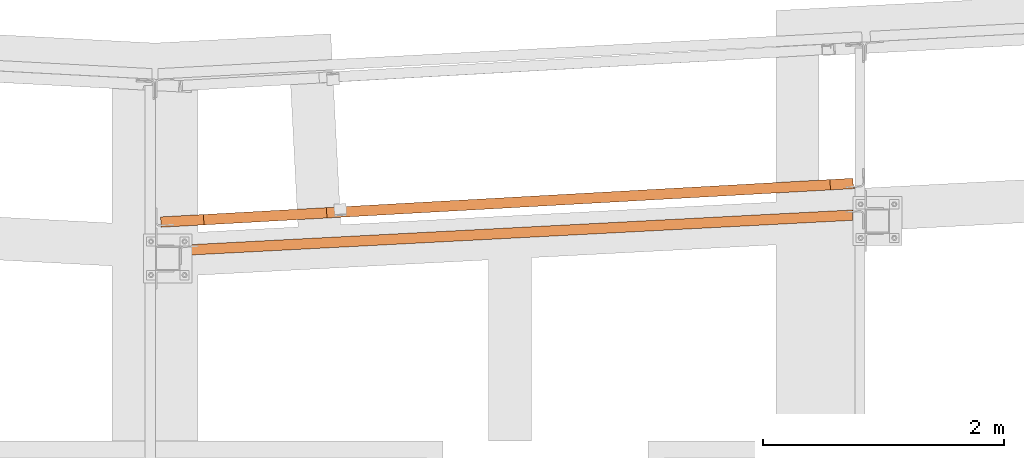
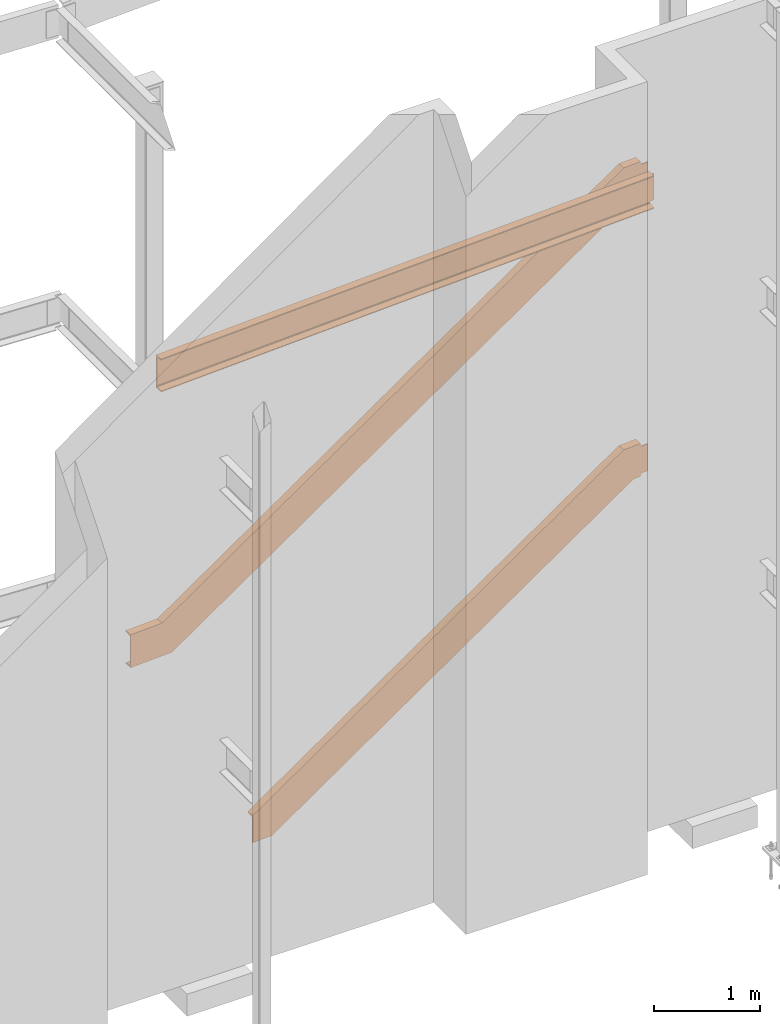
# One storey, part 15 of 89: 3 proxies.
"""IFC4 building model written with IfcOpenShell, lengths in feet."""

from ifc_helpers import new_model, entity, si_unit, converted_unit, derived_unit, direction, frame, origin, place, context, subcontext, project, spatial, face_set, faceted_brep, surface_model, source, transform, mapped, material, constituent, constituent_set, type_object, type_shapes, element, save


model = new_model("IFC4")

# Units and contexts
model_context = context("Model", 3, precision=0.0001, world=origin(), true_north=direction((6.12303176911189e-17, 1.0)))
body_context = subcontext(model_context, "Body", "Model", "MODEL_VIEW")
ifc_project = project(units=[converted_unit("LENGTHUNIT", "FOOT", entity("IfcRatioMeasure", 0.3048), si_unit("LENGTHUNIT", "METRE"), dimensions=[1, 0, 0, 0, 0, 0, 0]), converted_unit("AREAUNIT", "SQUARE FOOT", entity("IfcRatioMeasure", 0.09290304), si_unit("AREAUNIT", "SQUARE_METRE"), dimensions=[2, 0, 0, 0, 0, 0, 0]), converted_unit("VOLUMEUNIT", "CUBIC FOOT", entity("IfcRatioMeasure", 0.028316846592), si_unit("VOLUMEUNIT", "CUBIC_METRE"), dimensions=[3, 0, 0, 0, 0, 0, 0]), si_unit("PLANEANGLEUNIT", "RADIAN"), si_unit("MASSUNIT", "GRAM", prefix="KILO"), derived_unit("MASSDENSITYUNIT", [(si_unit("MASSUNIT", "GRAM", prefix="KILO"), 1), (si_unit("LENGTHUNIT", "METRE"), -3)]), derived_unit("MOMENTOFINERTIAUNIT", [(si_unit("LENGTHUNIT", "METRE"), 4)]), si_unit("TIMEUNIT", "SECOND"), si_unit("FREQUENCYUNIT", "HERTZ"), si_unit("THERMODYNAMICTEMPERATUREUNIT", "DEGREE_CELSIUS"), derived_unit("THERMALTRANSMITTANCEUNIT", [(si_unit("MASSUNIT", "GRAM", prefix="KILO"), 1), (si_unit("THERMODYNAMICTEMPERATUREUNIT", "KELVIN"), -1), (si_unit("TIMEUNIT", "SECOND"), -3)]), derived_unit("VOLUMETRICFLOWRATEUNIT", [(si_unit("LENGTHUNIT", "METRE"), 3), (si_unit("TIMEUNIT", "SECOND"), -1)]), si_unit("ELECTRICCURRENTUNIT", "AMPERE"), si_unit("ELECTRICVOLTAGEUNIT", "VOLT"), si_unit("POWERUNIT", "WATT"), si_unit("FORCEUNIT", "NEWTON"), si_unit("ILLUMINANCEUNIT", "LUX"), si_unit("LUMINOUSFLUXUNIT", "LUMEN"), si_unit("LUMINOUSINTENSITYUNIT", "CANDELA"), derived_unit("USERDEFINED", [(si_unit("MASSUNIT", "GRAM", prefix="KILO"), -1), (si_unit("LENGTHUNIT", "METRE"), -2), (si_unit("TIMEUNIT", "SECOND"), 3), (si_unit("LUMINOUSFLUXUNIT", "LUMEN"), 1)]), derived_unit("LINEARVELOCITYUNIT", [(si_unit("LENGTHUNIT", "METRE"), 1), (si_unit("TIMEUNIT", "SECOND"), -1)]), si_unit("PRESSUREUNIT", "PASCAL"), derived_unit("USERDEFINED", [(si_unit("LENGTHUNIT", "METRE"), -2), (si_unit("MASSUNIT", "GRAM", prefix="KILO"), 1), (si_unit("TIMEUNIT", "SECOND"), -2)]), derived_unit("LINEARFORCEUNIT", [(si_unit("MASSUNIT", "GRAM", prefix="KILO"), 1), (si_unit("LENGTHUNIT", "METRE"), 1), (si_unit("TIMEUNIT", "SECOND"), -2), (si_unit("LENGTHUNIT", "METRE"), -1)]), derived_unit("PLANARFORCEUNIT", [(si_unit("MASSUNIT", "GRAM", prefix="KILO"), 1), (si_unit("LENGTHUNIT", "METRE"), 1), (si_unit("TIMEUNIT", "SECOND"), -2), (si_unit("LENGTHUNIT", "METRE"), -2)])], contexts=[model_context])

# Site, building, storey
site_placement = place(None, origin())
site = spatial("IfcSite", under=ifc_project, at=site_placement, CompositionType="ELEMENT")
building_placement = place(site_placement, frame((-472.238160486, -49.138065117, 0.0)))
building = spatial("IfcBuilding", under=site, at=building_placement, CompositionType="ELEMENT")
storey_placement = place(building_placement, origin())
storey = spatial("IfcBuildingStorey", under=building, at=storey_placement, Name="Level 1", CompositionType="ELEMENT", Elevation=0.0)

# Proxies
ifc_material_1 = material(Name="Color 7720", Category="Materials")
ifc_material_2 = material()
ifc_constituent_1 = constituent(ifc_material_2)
ifc_constituent_2 = constituent(ifc_material_1, Name="Color 7720", Category="Materials")
ifc_constituent_set_1 = constituent_set(constituents=[ifc_constituent_1, ifc_constituent_2])
building_element_proxy_type_1 = type_object("IfcBuildingElementProxyType", Name="46B1", PredefinedType="NOTDEFINED", material=ifc_constituent_set_1)
shared_shape_1 = source(origin(), body_context, "Body", "Brep", [
    faceted_brep([(0.0, 0.282945034847103, 1.25000000000001), (0.0, 0.282945034847103, 0.0), (0.0148285209357653, 0.0, 0.0), (0.0148285209357653, 0.0, 0.0333340558078916), (0.00405689048207591, 0.20553495303659, 0.0676357025785599), (0.00314508419060644, 0.222933253516999, 0.0738152303317001), (0.00240032733219664, 0.2371440609312, 0.0856142600983816), (0.00191364833361263, 0.246430449426384, 0.101590647231962), (0.00174453187503332, 0.249657383688714, 0.119791666666682), (0.00174453187503332, 0.249657383688714, 1.13020833333334), (0.00191364833361263, 0.246430449426384, 1.14840935276806), (0.00240032733219664, 0.2371440609312, 1.16438573990165), (0.00314508419060644, 0.222933253516999, 1.17618476966832), (0.00405689048207591, 0.20553495303659, 1.18236429742146), (0.0148285209357653, 0.0, 1.21666594419213), (0.0148285209357653, 0.0, 1.25000000000001), (18.339448172324, 1.24407478683509, 0.125000000000011), (18.339448172324, 1.24407478683509, 1.12500000000001), (18.3411927041988, 1.2107871356767, 1.12500000000001), (18.3411927041988, 1.2107871356767, 0.125000000000011), (18.219500971703, 1.2377886204174, 0.12182831385465), (18.2060018576239, 1.23708116182615, 0.11279611588278), (18.1969820379655, 1.23660845310826, 0.0992784763485517), (18.1938146985057, 1.23644245988089, 0.0833333333333393), (18.1938146985057, 1.23644245988066, 0.0), (18.1938146985056, 1.23644245988419, 1.25000000000001), (18.1938146985056, 1.23644245988396, 1.16666666666668), (18.1969820379653, 1.23660845311122, 1.15072152365147), (18.2060018576237, 1.237081161829, 1.13720388411724), (18.2195009717029, 1.23778862042013, 1.12817168614537), (18.2354242624537, 1.23862312472727, 1.12500000000001), (18.2354242624539, 1.23862312472454, 0.125000000000011), (18.1989937882445, 0.952991719775582, 0.0), (18.1989937775088, 1.13761974550619, 0.0), (18.1989937882445, 0.952991719775582, 0.0333340558078916), (18.1989937775088, 1.13761974550619, 0.0640621568245159), (18.1978715889875, 1.15903237807242, 0.0676357025784746), (18.196959782696, 1.17643067855295, 0.0738152303317001), (18.196668108594, 1.19066523102822, 0.0856142600983496), (18.1963589983409, 1.1878943269528, 0.0833333333332895), (18.2004385121993, 1.20017472376878, 0.101590647231976), (18.198966120559, 1.19874990194103, 0.0992784763484948), (18.218201622917, 1.20434144623505, 0.119791666666675), (18.2078113893069, 1.20255324044263, 0.112796115882794), (18.2371687943283, 1.20533547357104, 0.125000000000011), (18.2371687943283, 1.20533547357104, 1.12500000000001), (18.2212455035775, 1.2045009692639, 1.12817168614537), (18.2182016229168, 1.20434144623812, 1.13020833333334), (18.2212455035775, 1.2045009692639, 0.12182831385465), (18.2004385121993, 1.20017472376878, 1.14840935276808), (18.2078113893069, 1.20255324044263, 1.13720388411722), (18.196668108594, 1.19066523102811, 1.16438573990163), (18.198966120559, 1.19874990194114, 1.15072152365151), (18.196959782696, 1.17643067855295, 1.17618476966827), (18.1963589983409, 1.18789432695269, 1.16666666666673), (18.1978715889875, 1.15903237807242, 1.18236429742152), (18.1989937882445, 0.952991719775582, 1.21666594419215), (18.1989937775088, 1.13761974550619, 1.18593784317547), (18.1989937882445, 0.952991719775582, 1.25000000000001), (18.1989937775088, 1.13761974550619, 1.25000000000001)], [[[0, 1, 2, 3, 4, 5, 6, 7, 8, 9, 10, 11, 12, 13, 14, 15]], [[16, 17, 18, 19]], [[20, 21, 22, 23, 24, 1, 0, 25, 26, 27, 28, 29, 30, 17, 16, 31]], [[32, 2, 1, 24, 33]], [[34, 3, 2, 32]], [[35, 36, 4, 3, 34]], [[37, 5, 4, 36]], [[38, 6, 5, 37, 39]], [[40, 7, 6, 38, 41]], [[42, 8, 7, 40, 43]], [[44, 19, 18, 45, 46, 47, 9, 8, 42, 48]], [[49, 10, 9, 47, 50]], [[51, 11, 10, 49, 52]], [[53, 12, 11, 51, 54]], [[55, 13, 12, 53]], [[56, 14, 13, 55, 57]], [[58, 15, 14, 56]], [[59, 25, 0, 15, 58]], [[57, 59, 25, 26, 54, 53, 55]], [[52, 27, 26, 54, 51]], [[50, 28, 27, 52, 49]], [[46, 29, 28, 50, 47]], [[29, 46, 45, 30]], [[17, 30, 45, 18]], [[59, 58, 56, 57]], [[19, 44, 31, 16]], [[48, 20, 31, 44]], [[43, 21, 20, 48, 42]], [[41, 22, 21, 43, 40]], [[39, 23, 22, 41, 38]], [[33, 24, 23, 39, 37, 36, 35]], [[34, 32, 33, 35]]]),
])
type_shapes(building_element_proxy_type_1, [shared_shape_1])
proxy_1_placement = place(building_placement, frame((231.291038536762, 1013.05140014163, 19.0208333333333)))
element("IfcBuildingElementProxy", 1, at=proxy_1_placement, inside=storey, type_object=building_element_proxy_type_1, material=ifc_material_1, Name="46B1:46B1", ObjectType="46B1:46B1", PredefinedType="NOTDEFINED", context=body_context, shape_type="MappedRepresentation", body=[
    mapped(shared_shape_1, transform((0.0, 0.0, 0.0), scale=1.0)),
])
ifc_material_3 = material(Name="Color 7718", Category="Materials")
ifc_constituent_3 = constituent(ifc_material_3, Name="Color 7718", Category="Materials")
ifc_constituent_4 = constituent(ifc_material_1, Name="Color 7720", Category="Materials")
ifc_constituent_set_2 = constituent_set(constituents=[ifc_constituent_3, ifc_constituent_4])
ifc_constituent_5 = constituent(ifc_material_2)
ifc_constituent_6 = constituent(ifc_material_3, Name="Color 7718", Category="Materials")
ifc_constituent_set_3 = constituent_set(constituents=[ifc_constituent_5, ifc_constituent_6])
building_element_proxy_type_2 = type_object("IfcBuildingElementProxyType", Name="c633", PredefinedType="NOTDEFINED", material=ifc_constituent_set_3)
shared_shape_2 = source(origin(), body_context, "Body", "SurfaceModel", [
    surface_model("IfcFaceBasedSurfaceModel", [(0.0, 0.282893515539058, 1.21666605017325), (0.0, 0.282893515539058, 1.25000010598113), (0.0157808948881382, 0.0, 1.25000010598113), (0.0157808948881382, 0.0, 1.05981126097277e-07), (0.0, 0.282893515539058, 1.05981126097277e-07), (0.0, 0.282893515539058, 0.0333341617890053), (0.0114634472786008, 0.0773959867976828, 0.0676358085596753), (0.0124338150790777, 0.0600008542412525, 0.0738153363128156), (0.0132264045592194, 0.0457926343649433, 0.0856143660794952), (0.0137443409167588, 0.03650793675763, 0.101590753213076), (0.0139243190189688, 0.0332815900630976, 0.119791772647796), (0.0139243190189688, 0.0332815900630976, 1.13020843931446), (0.0137443409167588, 0.03650793675763, 1.14840945874918), (0.0132264045592194, 0.0457926343649433, 1.16438584588276), (0.0124338150790777, 0.0600008542412525, 1.17618487564944), (0.0114634472786008, 0.0773959867976828, 1.18236440340258), (1.1829579478117, 0.0651096521353338, 1.25000010598113), (1.54041586807736, 0.0850500380290669, 1.05981126097277e-07), (1.52463497321222, 0.367943553569262, 1.05981126097277e-07), (1.51510255537875, 0.367411798419084, 0.0333341617890053), (1.51675688640427, 0.161367079219076, 0.0676358085596682), (1.51596011729359, 0.143873368928098, 0.0738153363128937), (1.5133785814605, 0.129476927286532, 0.0856143660796356), (1.50932780892359, 0.119937369419631, 0.101590753213179), (1.50430290818269, 0.116420674444271, 0.119791772647845), (1.215357755968, 0.100302195846666, 1.13020843931446), (1.20997289902272, 0.103238194260143, 1.14840945874916), (1.20488625377067, 0.112268031607982, 1.16438584588268), (1.20071953897724, 0.126288029718921, 1.17618487564921), (1.19798203426575, 0.143584584540804, 1.18236440340245), (1.17670947073407, 0.348534922823319, 1.21666605017314), (1.16717705292356, 0.348003167674392, 1.25000010598113), (19.146729075398, 1.06719475719137, 10.7812494701982), (19.1448675031324, 1.10045891734762, 10.7864584393145), (19.146729075398, 1.06719475719137, 11.8020834393145), (19.1448675031324, 1.10058098766012, 10.7812494701982), (19.1448675031324, 1.10058098766012, 11.7973436779619), (19.1448675031324, 1.10058098766012, 11.8020834393145), (18.234375559773, 1.30010491344137, 11.9166674084307), (18.243912302937, 1.30059319469137, 11.883332676375), (18.2651830548902, 1.09563714000387, 11.8490309185625), (18.2679296369214, 1.07836419078512, 11.8428511089922), (18.2501684064527, 1.01720696422262, 11.9166674084307), (18.2720952863355, 1.06432610484762, 11.8310522503496), (18.2771764630933, 1.05529290172262, 11.8150762982012), (18.2825628156324, 1.05236321422262, 11.7968744701982), (18.5715032453199, 1.06847649547262, 10.7864584393145), (18.5831609601636, 1.09594231578512, 10.7404818005205), (18.5839544171949, 1.11345940562887, 10.7343019909502), (18.6076207990308, 1.03710442516012, 10.6666674084307), (18.5823064679761, 1.31951409312887, 10.7000002331377), (18.5918432111402, 1.32000237437887, 10.6666674084307), (18.5765386457105, 1.07201653453512, 10.7682566113115), (18.580582224812, 1.08153801891012, 10.7522806591631), (18.8763128156324, 1.05211907359762, 11.8437494701982), (18.8763128156324, 1.05211907359762, 11.9166674084307), (18.8794866437574, 1.05230217906637, 11.8278040356279), (18.8885045880933, 1.05279046031637, 11.8142866558672), (18.9179235334058, 1.05443840953512, 10.7812494701982), (18.9179235334058, 1.05443840953512, 11.8020834393145), (18.9019933576245, 1.05352288219137, 11.8052553600908), (18.8885045880933, 1.05279046031637, 10.7690462536455), (18.8794866437574, 1.05230217906637, 10.7555288738848), (18.8763128156324, 1.05211907359762, 10.7395834393145), (18.8763128156324, 1.05211907359762, 10.6666674084307), (18.9019933576245, 1.05352288219137, 10.7780775494219), (18.8605352277417, 1.33501702281637, 10.6666674084307), (18.8721319074292, 1.12707024547262, 10.6666674084307), (18.8605352277417, 1.33501702281637, 10.7000002331377), (18.8719945783277, 1.12951165172262, 10.7343019909502), (18.8721319074292, 1.12707024547262, 10.7351660198809), (18.872818552937, 1.11461907359762, 10.7395834393145), (18.8731389875074, 1.11211663219137, 10.7404818005205), (18.8762822980542, 1.09801751109762, 10.7522806591631), (18.8770299787183, 1.09618645641012, 10.7555288738848), (18.8859411115308, 1.08928948375387, 10.7682566113115), (18.886475169148, 1.08916741344137, 10.7690462536455), (18.9000554914136, 1.08831292125387, 10.7780775494219), (18.9108587140699, 1.08855706187887, 10.7802271313311), (18.9160619611402, 1.08782464000387, 10.7859892315508), (18.9108587140699, 1.08855706187887, 11.8031057781816), (18.9160619611402, 1.08782464000387, 11.7973436779619), (18.9000554914136, 1.08831292125387, 11.8052553600908), (18.886475169148, 1.08916741344137, 11.8142866558672), (18.8859411115308, 1.08928948375387, 11.8150762982012), (18.8770299787183, 1.09618645641012, 11.8278040356279), (18.8762822980542, 1.09801751109762, 11.8310522503496), (18.8731389875074, 1.11211663219137, 11.8428511089922), (18.872818552937, 1.11461907359762, 11.8437494701982), (18.8721319074292, 1.12707024547262, 11.8481687969805), (18.8719945783277, 1.12951165172262, 11.8490309185625), (18.8605352277417, 1.33501702281637, 11.883332676375), (18.8605352277417, 1.33501702281637, 11.9166674084307), (18.8721319074292, 1.12707024547262, 11.9166674084307), (18.9160619611402, 1.08782464000387, 11.8020834393145), (18.9160619611402, 1.08782464000387, 10.7812494701982)], [face_set([[[0, 1, 2, 3, 4, 5, 6, 7, 8, 9, 10, 11, 12, 13, 14, 15]], [[16, 2, 3, 17]], [[17, 3, 4, 18]], [[18, 4, 5, 19]], [[19, 5, 6, 20]], [[20, 6, 7, 21]], [[21, 7, 8, 22]], [[22, 8, 9, 23]], [[23, 9, 10, 24]], [[24, 10, 11, 25]], [[25, 11, 12, 26]], [[26, 12, 13, 27]], [[27, 13, 14, 28]], [[28, 14, 15, 29]], [[29, 15, 0, 30]], [[30, 0, 1, 31]], [[31, 1, 2, 16]], [[18, 19, 20, 21, 22, 23, 24, 25, 26, 27, 28, 29, 30, 31, 16, 17]]]), face_set([[[32, 33, 34]], [[33, 32, 35]], [[36, 34, 33]], [[34, 36, 37]], [[38, 39, 40]], [[40, 41, 42]], [[38, 40, 42]], [[42, 43, 44]], [[43, 42, 41]], [[44, 45, 42]], [[42, 45, 46]], [[47, 48, 49]], [[50, 51, 48]], [[48, 51, 49]], [[46, 52, 49]], [[53, 49, 52]], [[49, 53, 47]], [[46, 49, 42]], [[54, 55, 42]], [[56, 42, 57]], [[42, 56, 54]], [[58, 59, 60]], [[60, 57, 61]], [[34, 59, 32]], [[49, 57, 42]], [[62, 61, 49]], [[63, 49, 64]], [[49, 63, 62]], [[65, 60, 61]], [[58, 32, 59]], [[58, 60, 65]], [[61, 57, 49]], [[51, 66, 67]], [[67, 64, 49]], [[67, 49, 51]], [[68, 66, 51]], [[51, 50, 68]], [[69, 68, 50]], [[50, 48, 69]], [[70, 69, 48]], [[71, 48, 47]], [[48, 71, 70]], [[71, 47, 72]], [[73, 72, 47]], [[47, 53, 73]], [[74, 73, 53]], [[74, 52, 75]], [[52, 74, 53]], [[52, 46, 75]], [[76, 75, 46]], [[46, 77, 76]], [[78, 77, 79]], [[33, 79, 46]], [[77, 46, 79]], [[46, 45, 36]], [[36, 33, 46]], [[80, 81, 82]], [[36, 45, 81]], [[82, 45, 83]], [[45, 82, 81]], [[45, 84, 83]], [[84, 45, 44]], [[85, 84, 44]], [[86, 44, 43]], [[44, 86, 85]], [[87, 86, 43]], [[43, 41, 87]], [[87, 88, 41]], [[41, 88, 89]], [[90, 40, 41]], [[90, 41, 89]], [[91, 90, 40]], [[40, 39, 91]], [[92, 91, 39]], [[39, 38, 92]], [[93, 38, 42]], [[38, 93, 92]], [[93, 42, 55]], [[37, 94, 59]], [[59, 34, 37]], [[59, 94, 80]], [[80, 82, 60]], [[80, 60, 59]], [[83, 57, 82]], [[60, 82, 57]], [[85, 56, 84]], [[84, 57, 83]], [[57, 84, 56]], [[87, 88, 54]], [[86, 87, 54]], [[85, 54, 56]], [[54, 85, 86]], [[93, 88, 89]], [[55, 54, 88]], [[89, 90, 93]], [[91, 92, 93]], [[55, 88, 93]], [[93, 90, 91]], [[80, 94, 81]], [[36, 81, 94]], [[94, 37, 36]], [[67, 71, 70]], [[64, 63, 71]], [[70, 69, 67]], [[68, 66, 67]], [[64, 71, 67]], [[67, 69, 68]], [[72, 73, 63]], [[71, 72, 63]], [[74, 62, 63]], [[74, 63, 73]], [[76, 61, 75]], [[75, 62, 74]], [[62, 75, 61]], [[61, 76, 77]], [[77, 65, 61]], [[77, 78, 65]], [[58, 65, 78]], [[58, 78, 95]], [[95, 35, 58]], [[32, 58, 35]], [[79, 95, 78]], [[95, 79, 35]], [[33, 35, 79]]])]),
    surface_model("IfcFaceBasedSurfaceModel", [(1.16717705292294, 0.348003167679508, 1.25000010598117), (1.17670946621132, 0.348534922576164, 1.21666604734706), (1.19798202508966, 0.143584584033874, 1.18236439766813), (1.20071952896288, 0.126288029165266, 1.17618486939107), (1.2048862421556, 0.11226803096497, 1.16438583862401), (1.20997288524029, 0.103238193496281, 1.14840945013587), (1.21535773971644, 0.100302194945016, 1.13020842915798), (1.50430275485795, 0.116420665895816, 0.119791676823191), (1.50932765312962, 0.119937360733729, 0.101590655845309), (1.51337842349923, 0.129476918479895, 0.0856142673571636), (1.51595995773167, 0.143873360032217, 0.0738152365901108), (1.51675672600399, 0.161367070276356, 0.0676357083130323), (1.51510239032504, 0.367411789216931, 0.0333340586340967), (1.52463480361342, 0.367943544113587, 0.0), (1.54041569850165, 0.0850500285740736, 0.0), (1.18295794781113, 0.065109652139995, 1.25000010598118), (18.2501615934951, 1.01718430911546, 11.9166667726478), (18.6076193441857, 1.03712468554954, 10.6666666666667), (18.5918384492975, 1.32001820108906, 10.6666666666667), (18.5823060360091, 1.3194864461924, 10.7000007253008), (18.583960371688, 1.11344172725171, 10.7343023749797), (18.5831636034157, 1.09594801700769, 10.7404819032568), (18.5805820691832, 1.08155157545536, 10.7522809340239), (18.5765312988136, 1.07201201770908, 10.768257322512), (18.5715064005419, 1.06849532287129, 10.7864583434899), (18.2825613854004, 1.05237685192049, 11.7968750958246), (18.2771765309242, 1.05531285047175, 11.8150761168025), (18.2720898878396, 1.06434268794033, 11.8310525052906), (18.2679231746468, 1.07836268614062, 11.8428515360577), (18.2651856707736, 1.09565924100934, 11.8490310643348), (18.2439131118953, 1.30060957955163, 11.8833327140137), (18.2343806986069, 1.30007782465498, 11.9166667726478)], [face_set([[[0, 1, 2, 3, 4, 5, 6, 7, 8, 9, 10, 11, 12, 13, 14, 15]], [[16, 17, 18, 19, 20, 21, 22, 23, 24, 25, 26, 27, 28, 29, 30, 31]], [[30, 1, 0, 31]], [[29, 2, 1, 30]], [[28, 3, 2, 29]], [[27, 4, 3, 28]], [[26, 5, 4, 27]], [[25, 6, 5, 26]], [[24, 7, 6, 25]], [[23, 8, 7, 24]], [[22, 9, 8, 23]], [[21, 10, 9, 22]], [[20, 11, 10, 21]], [[19, 12, 11, 20]], [[18, 13, 12, 19]], [[17, 14, 13, 18]], [[16, 15, 14, 17]], [[31, 0, 15, 16]]])]),
])
type_shapes(building_element_proxy_type_2, [shared_shape_2])
proxy_2_placement = place(building_placement, frame((230.637679493938, 1013.81543463734, 8.35416656068554)))
element("IfcBuildingElementProxy", 2, at=proxy_2_placement, inside=storey, type_object=building_element_proxy_type_2, material=ifc_constituent_set_2, PredefinedType="NOTDEFINED", context=body_context, shape_type="MappedRepresentation", body=[
    mapped(shared_shape_2, transform((0.0, 0.0, 0.0), scale=1.0)),
])
ifc_constituent_7 = constituent(ifc_material_1, Name="Color 7720", Category="Materials")
ifc_constituent_8 = constituent(ifc_material_3, Name="Color 7718", Category="Materials")
ifc_constituent_set_4 = constituent_set(constituents=[ifc_constituent_7, ifc_constituent_8])
ifc_constituent_9 = constituent(ifc_material_2)
ifc_constituent_10 = constituent(ifc_material_3, Name="Color 7718", Category="Materials")
ifc_constituent_set_5 = constituent_set(constituents=[ifc_constituent_9, ifc_constituent_10])
building_element_proxy_type_3 = type_object("IfcBuildingElementProxyType", Name="c645", PredefinedType="NOTDEFINED", material=ifc_constituent_set_5)
shared_shape_3 = source(origin(), body_context, "Body", "SurfaceModel", [
    surface_model("IfcFaceBasedSurfaceModel", [(0.0139243190023137, 0.0332815900634387, 2.09624850408003e-07), (0.0157808948715115, 0.0, 2.09624850408003e-07), (0.722813025380731, 0.0394409879380646, 0.0), (0.707032130492536, 0.322334503477578, 0.0), (0.644163575117972, 0.318827452203323, 1.86396294274208e-08), (0.59093357519447, 0.109721072660591, 3.78203046267457e-08), (0.580249256119231, 0.0916757965750321, 4.127575140197e-08), (0.558788689231989, 0.0762262095331607, 4.78734917126522e-08), (0.529174907295726, 0.0652606480915665, 5.68071121454194e-08), (0.495027475472199, 0.0601193856492728, 6.69846947089656e-08), (14.0899012045049, 0.785108887443016, 8.35416725965615), (14.0741203096167, 1.06800240298253, 8.35416725965615), (14.0645878963283, 1.06747064808587, 8.38750131829025), (14.0662422320072, 0.861425929145184, 8.42180296796918), (14.0654454637349, 0.843932218901159, 8.42798249624626), (14.0628639295024, 0.829535777348838, 8.43978152701333), (14.0588131591329, 0.819996219602558, 8.45575791550147), (14.0537882608612, 0.816479524764759, 8.47395893647935), (13.7648432457196, 0.800361053813958, 9.48437568881412), (13.7594583912435, 0.803297052365224, 9.50257670979201), (13.7543717481588, 0.812326889833798, 9.51855309828014), (13.7502050349661, 0.826346888034095, 9.53035212904722), (13.7474675310929, 0.843643442902817, 9.53653165732429), (13.7261949722145, 1.04859378144511, 9.57083330700323), (13.7166625589261, 1.04806202654845, 9.60416736563733), (13.7324434538143, 0.765168511008937, 9.60416736563733), (0.0, 0.28289351554065, 1.03152299268716), (0.0, 0.282893515540536, 0.992231363194522), (0.0114634472827504, 0.0773959867992744, 0.951799211653524), (0.012433815083142, 0.0600008542429578, 0.944515258080127), (0.0132264045632837, 0.0457926343665349, 0.930607466341931), (0.0137443409208515, 0.0365079367591079, 0.911775725989011), (0.0139243190231184, 0.0332815900646892, 0.890321759626913), (0.0157808948922877, 0.0, 1.03152299268714)], [face_set([[[0, 1, 2, 3, 4, 5, 6, 7, 8, 9]], [[10, 11, 12, 13, 14, 15, 16, 17, 18, 19, 20, 21, 22, 23, 24, 25]], [[26, 24, 23, 27]], [[27, 23, 22, 28]], [[28, 22, 21, 29]], [[29, 21, 20, 30]], [[30, 20, 19, 31]], [[31, 19, 18, 32]], [[32, 18, 17, 9, 0]], [[8, 9, 17, 16]], [[7, 8, 16, 15]], [[6, 7, 15, 14]], [[5, 6, 14, 13]], [[4, 5, 13, 12]], [[3, 4, 12, 11]], [[2, 3, 11, 10]], [[1, 2, 10, 25, 33]], [[33, 25, 24, 26]], [[33, 26, 27, 28, 29, 30, 31, 32, 0, 1]]])]),
    surface_model("IfcFaceBasedSurfaceModel", [(14.6290131113597, 0.8151901459795, 8.46875069897064), (14.6271515390941, 0.84845430613575, 8.47395871441254), (14.6290131113597, 0.8151901459795, 9.48958371441254), (14.6271515390941, 0.84857637644825, 8.46875069897064), (14.6271515390941, 0.84857637644825, 9.48484490673432), (14.6271515390941, 0.84857637644825, 9.48958371441254), (13.7166595957347, 1.04803926707325, 9.60416768352875), (13.7261963388988, 1.0485885834795, 9.57083295147308), (13.7474670908519, 0.843632528792, 9.53653119366058), (13.7501984140941, 0.82635957957325, 9.53035233776459), (13.7324371836253, 0.7651413178545, 9.60416768352875), (13.7543793222972, 0.81232149363575, 9.51855347912201), (13.759460499055, 0.80328829051075, 9.50257657329926), (13.7648468515941, 0.80035860301075, 9.48437569897064), (14.0537872812816, 0.81647188426075, 8.47395871441254), (14.0654449961253, 0.84393770457325, 8.42798302929291), (14.0662384531566, 0.861454794417, 8.4218032197226), (14.0899048349925, 0.78509981394825, 8.35416768352875), (14.0645905039378, 1.06744844676075, 8.3875014619101), (14.0741272471019, 1.067997763167, 8.35416768352875), (14.0588074228831, 0.82001192332325, 8.45575784008392), (14.0628662607738, 0.82953340769825, 8.43978188793549), (14.3585968515941, 0.80011446238575, 9.53125069897064), (14.3585968515941, 0.80011446238575, 9.60416768352875), (14.36175542093, 0.8002975678545, 9.51530526440033), (14.370788624055, 0.8007858491045, 9.50178788463959), (14.4001923105785, 0.80243379832325, 8.46875069897064), (14.4001923105785, 0.80243379832325, 9.48958371441254), (14.3842773935863, 0.8015182709795, 9.4927556351889), (14.370788624055, 0.8007858491045, 8.45654652874359), (14.36175542093, 0.8002975678545, 8.44302914898285), (14.3585968515941, 0.80011446238575, 8.42708371441254), (14.3585968515941, 0.80011446238575, 8.35416768352875), (14.3842773935863, 0.8015182709795, 8.46557877819428), (14.3428192637035, 1.0830124116045, 8.35416768352875), (14.354415943391, 0.87506563426075, 8.35416768352875), (14.3428192637035, 1.0830124116045, 8.3875014619101), (14.3542786142894, 0.87750704051075, 8.4218032197226), (14.354415943391, 0.87506563426075, 8.42266629497894), (14.3551025888988, 0.86261446238575, 8.42708371441254), (14.3554230234691, 0.8601120209795, 8.42798302929291), (14.358566334016, 0.84601289988575, 8.43978188793549), (14.35931401468, 0.84418184519825, 8.44302914898285), (14.3682251474925, 0.837284872542, 8.45575784008392), (14.3687592051097, 0.8371628022295, 8.45654652874359), (14.3823395273753, 0.836308310042, 8.46557877819428), (14.3931427500316, 0.83649141551075, 8.46772740642914), (14.3983307383128, 0.83575899363575, 8.47348950664887), (14.3931427500316, 0.83649141551075, 9.49060700695404), (14.3983307383128, 0.83575899363575, 9.48484490673432), (14.3823395273753, 0.836308310042, 9.4927556351889), (14.3687592051097, 0.8371628022295, 9.50178788463959), (14.3682251474925, 0.837284872542, 9.50257657329926), (14.35931401468, 0.84418184519825, 9.51530526440033), (14.358566334016, 0.84601289988575, 9.51855347912201), (14.3554230234691, 0.8601120209795, 9.53035233776459), (14.3551025888988, 0.86261446238575, 9.53125069897064), (14.354415943391, 0.87506563426075, 9.53566907207855), (14.3542786142894, 0.87750704051075, 9.53653119366058), (14.3428192637035, 1.0830124116045, 9.57083295147308), (14.3428192637035, 1.0830124116045, 9.60416768352875), (14.354415943391, 0.87506563426075, 9.60416768352875), (14.3983307383128, 0.83575899363575, 9.48958371441254), (14.3983307383128, 0.83575899363575, 8.46875069897064)], [face_set([[[0, 1, 2]], [[1, 0, 3]], [[4, 2, 1]], [[2, 4, 5]], [[6, 7, 8]], [[8, 9, 10]], [[6, 8, 10]], [[10, 11, 12]], [[11, 10, 9]], [[12, 13, 10]], [[10, 13, 14]], [[15, 16, 17]], [[18, 19, 16]], [[16, 19, 17]], [[14, 20, 17]], [[21, 17, 20]], [[17, 21, 15]], [[14, 17, 10]], [[22, 23, 10]], [[24, 10, 25]], [[10, 24, 22]], [[26, 27, 28]], [[28, 25, 29]], [[2, 27, 0]], [[17, 25, 10]], [[30, 29, 17]], [[31, 17, 32]], [[17, 31, 30]], [[33, 28, 29]], [[26, 0, 27]], [[26, 28, 33]], [[29, 25, 17]], [[19, 34, 35]], [[35, 32, 17]], [[35, 17, 19]], [[36, 34, 19]], [[19, 18, 36]], [[37, 36, 18]], [[18, 16, 37]], [[38, 37, 16]], [[39, 16, 15]], [[16, 39, 38]], [[39, 15, 40]], [[41, 40, 15]], [[15, 21, 41]], [[42, 41, 21]], [[42, 20, 43]], [[20, 42, 21]], [[20, 14, 43]], [[44, 43, 14]], [[14, 45, 44]], [[46, 45, 47]], [[1, 47, 14]], [[45, 14, 47]], [[14, 13, 4]], [[4, 1, 14]], [[48, 49, 50]], [[4, 13, 49]], [[50, 13, 51]], [[13, 50, 49]], [[13, 52, 51]], [[52, 13, 12]], [[53, 52, 12]], [[54, 12, 11]], [[12, 54, 53]], [[55, 54, 11]], [[11, 9, 55]], [[55, 56, 9]], [[9, 56, 57]], [[58, 8, 9]], [[58, 9, 57]], [[59, 58, 8]], [[8, 7, 59]], [[60, 59, 7]], [[7, 6, 60]], [[61, 6, 10]], [[6, 61, 60]], [[61, 10, 23]], [[5, 62, 27]], [[27, 2, 5]], [[27, 62, 48]], [[48, 50, 28]], [[48, 28, 27]], [[51, 25, 50]], [[28, 50, 25]], [[53, 24, 52]], [[52, 25, 51]], [[25, 52, 24]], [[55, 56, 22]], [[54, 55, 22]], [[53, 22, 24]], [[22, 53, 54]], [[61, 56, 57]], [[23, 22, 56]], [[57, 58, 61]], [[59, 60, 61]], [[23, 56, 61]], [[61, 58, 59]], [[48, 62, 49]], [[4, 49, 62]], [[62, 5, 4]], [[35, 39, 38]], [[32, 31, 39]], [[38, 37, 35]], [[36, 34, 35]], [[32, 39, 35]], [[35, 37, 36]], [[40, 41, 31]], [[39, 40, 31]], [[42, 30, 31]], [[42, 31, 41]], [[44, 29, 43]], [[43, 30, 42]], [[30, 43, 29]], [[29, 44, 45]], [[45, 33, 29]], [[45, 46, 33]], [[26, 33, 46]], [[26, 46, 63]], [[63, 3, 26]], [[0, 26, 3]], [[47, 63, 46]], [[63, 47, 3]], [[1, 3, 47]]])]),
])
type_shapes(building_element_proxy_type_3, [shared_shape_3])
proxy_3_placement = place(building_placement, frame((235.155197093718, 1014.06743924855, -6.98970643142616e-07)))
element("IfcBuildingElementProxy", 3, at=proxy_3_placement, inside=storey, type_object=building_element_proxy_type_3, material=ifc_constituent_set_4, PredefinedType="NOTDEFINED", context=body_context, shape_type="MappedRepresentation", body=[
    mapped(shared_shape_3, transform((0.0, 0.0, 0.0), scale=1.0)),
])

save(model, "model.ifc")
